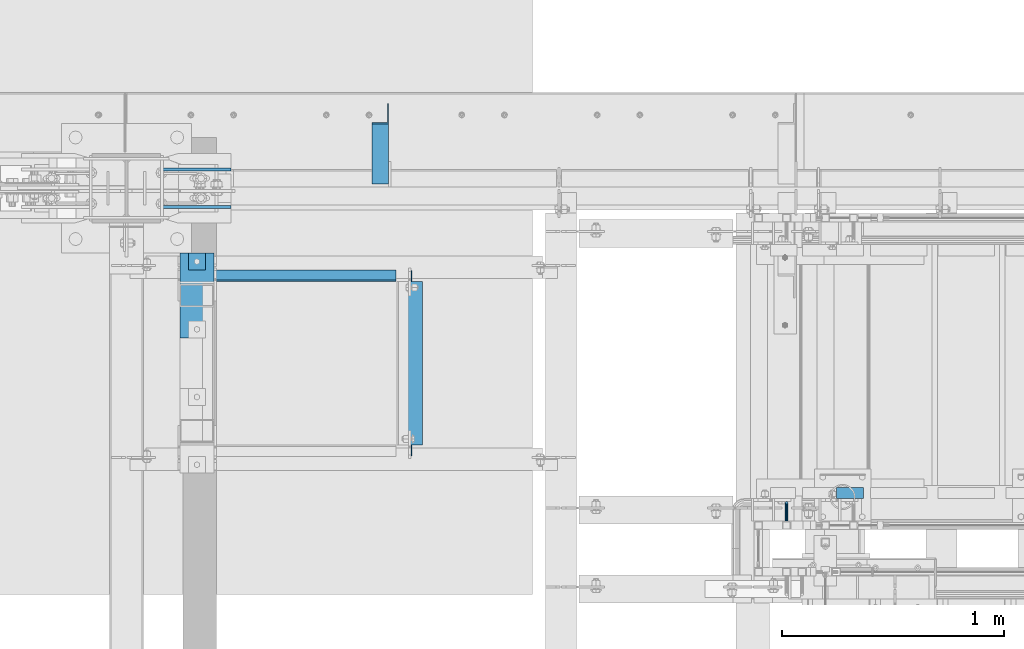
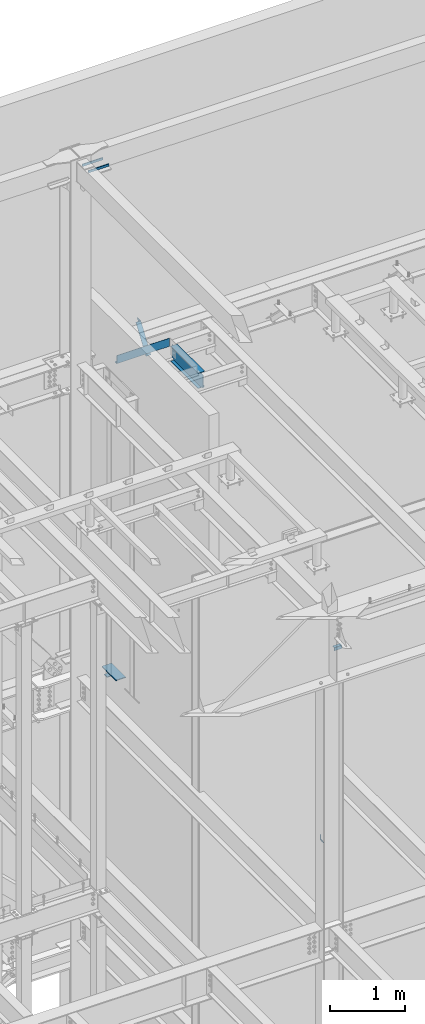
# One storey, part 928 of 1179: 8 beams, 1 member, 8 elements without a shape of their own.
"""IFC2X3 building model written with IfcOpenShell, lengths in millimetres."""

from ifc_helpers import new_model, si_unit, frame, origin_with_axes, place, context, subcontext, project, spatial, faceted_brep, material, type_object, element, aggregate, save


model = new_model("IFC2X3")

# Units and contexts
model_context = context("Model", 3, precision=1e-05, world=origin_with_axes())
body_context = subcontext(model_context, "Body", "Model", "MODEL_VIEW")
ifc_project = project(units=[si_unit("LENGTHUNIT", "METRE", prefix="MILLI"), si_unit("AREAUNIT", "SQUARE_METRE"), si_unit("VOLUMEUNIT", "CUBIC_METRE"), si_unit("MASSUNIT", "GRAM", prefix="KILO"), si_unit("TIMEUNIT", "SECOND"), si_unit("PLANEANGLEUNIT", "RADIAN"), si_unit("SOLIDANGLEUNIT", "STERADIAN"), si_unit("THERMODYNAMICTEMPERATUREUNIT", "DEGREE_CELSIUS"), si_unit("LUMINOUSINTENSITYUNIT", "LUMEN")], contexts=[model_context])

# Site, building, storey
site_placement = place(None, origin_with_axes())
site = spatial("IfcSite", under=ifc_project, at=site_placement, CompositionType="ELEMENT")
building_placement = place(site_placement, origin_with_axes())
building = spatial("IfcBuilding", under=site, at=building_placement, Name="Undefined", CompositionType="ELEMENT")
storey_placement = place(building_placement, origin_with_axes())
storey = spatial("IfcBuildingStorey", under=building, at=storey_placement, Name="Undefined", CompositionType="ELEMENT", Elevation=0.0)

# Assembly, beam
assembly_1_placement = place(storey_placement, origin_with_axes())
assembly_1 = element("IfcElementAssembly", 1, at=assembly_1_placement, inside=storey, Name="STAIR", AssemblyPlace="NOTDEFINED", PredefinedType="RIGID_FRAME")
ifc_material_1 = material(Name="STEEL/A36")
beam_type_1 = type_object("IfcBeamType", Name="L2X2X3/16", PredefinedType="NOTDEFINED")
beam_1_placement = place(assembly_1_placement, frame((19777.0749999898, 39827.2000000125, 8068.27050963414), z_axis=(0.0, 1.0, 0.0), x_axis=(-1.0, 0.0, 0.0)))
beam_1 = element("IfcBeam", 2, at=beam_1_placement, type_object=beam_type_1, material=ifc_material_1, Name="ANGLE", ObjectType="L2X2X3/16", context=body_context, shape_type="Brep", body=[
    faceted_brep([(0.0, 25.3999999999996, -25.4000000000015), (0.0, 25.3999999999996, 25.4000000000015), (120.650000000842, 25.3999999999996, 25.4000000000015), (120.650000000842, 25.3999999999996, -25.4000000000015), (0.0, 20.6374999999998, 25.4000000000015), (120.650000000842, 20.6374999999998, 25.4000000000015), (0.0, 20.6374999999998, -20.6374999999971), (120.650000000842, 20.6374999999998, -20.6374999999971), (0.0, -25.3999999999996, -20.6374999999971), (120.650000000842, -25.3999999999996, -20.6374999999971), (0.0, -25.3999999999996, -25.4000000000015), (120.650000000842, -25.3999999999996, -25.4000000000015)], [[[0, 1, 2, 3]], [[1, 4, 5, 2]], [[4, 6, 7, 5]], [[6, 8, 9, 7]], [[8, 10, 11, 9]], [[10, 0, 3, 11]], [[5, 7, 9, 11, 3, 2]], [[10, 8, 6, 4, 1, 0]]]),
])
aggregate(assembly_1, [beam_1])

assembly_2_placement = place(storey_placement, origin_with_axes())
assembly_2 = element("IfcElementAssembly", 3, at=assembly_2_placement, inside=storey, Name="GUARDRAIL", AssemblyPlace="NOTDEFINED", PredefinedType="RIGID_FRAME")
beam_type_2 = type_object("IfcBeamType", PredefinedType="NOTDEFINED")
beam_2_placement = place(assembly_2_placement, frame((19430.9999992195, 39700.200000778, 5054.6), z_axis=(0.0, 0.0, 1.0), x_axis=(0.0, 1.0, 0.0)))
beam_2 = element("IfcBeam", 4, at=beam_2_placement, type_object=beam_type_2, material=ifc_material_1, Name="BRACKET", context=body_context, shape_type="Brep", body=[
    faceted_brep([(0.0, -6.34999999999854, 0.0), (0.0, -4.49012806053361, -4.49012806053452), (69.849999425729, -4.49012806053361, -4.49012806053452), (69.849999425729, -6.34999999999854, 0.0), (0.0, 0.0, -6.34999999999991), (69.849999425729, 0.0, -6.34999999999991), (0.0, 4.49012806053361, -4.49012806053452), (69.849999425729, 4.49012806053361, -4.49012806053452), (0.0, 6.34999999999854, 0.0), (69.849999425729, 6.34999999999854, 0.0), (0.0, 4.49012806053361, 4.49012806053452), (69.849999425729, 4.49012806053361, 4.49012806053452), (0.0, 0.0, 6.34999999999991), (69.849999425729, 0.0, 6.34999999999991), (0.0, -4.49012806053361, 4.49012806053452), (69.849999425729, -4.49012806053361, 4.49012806053452), (79.3749993303718, 0.0, -3.79778396764323), (78.445063360632, -4.49012806053361, -2.18708762028064), (76.1999993303689, -6.34999999999854, 1.70147734638658), (73.9549353000984, -4.49012806053361, 5.59004231305425), (73.024999330366, 0.0, 7.20073866041639), (73.9549353000984, 4.49012806053361, 5.59004231305425), (76.1999993303689, 6.34999999999854, 1.70147734638658), (78.445063360632, 4.49012806053361, -2.18708762028064), (84.7370868552753, 4.49012806053361, 4.10493587436031), (86.3477832026401, 0.0, 3.17499990462693), (80.8485218886053, 6.34999999999854, 6.34999990462893), (76.9599569219426, 4.49012806053361, 8.59506393489755), (75.3492605745778, 0.0, 9.52499990463093), (76.9599569219426, -4.49012806053361, 8.59506393489755), (80.8485218886053, -6.34999999999854, 6.34999990462893), (84.7370868552753, -4.49012806053361, 4.10493587436031), (87.0401272955278, 4.49012806053361, 12.6999998092651), (88.8999992349927, 0.0, 12.6999998092651), (82.5499992349942, 6.34999999999854, 12.6999998092651), (78.0598711744606, 4.49012806053361, 12.6999998092651), (76.1999992349956, 0.0, 12.6999998092651), (78.0598711744606, -4.49012806053361, 12.6999998092651), (82.5499992349942, -6.34999999999854, 12.6999998092651), (87.0401272955278, -4.49012806053361, 12.6999998092651), (87.0401272955278, -4.49012806053361, 76.2000000000007), (82.5499992349942, -6.34999999999854, 76.2000000000007), (88.8999992349927, 0.0, 76.2000000000003), (87.0401272955278, 4.49012806053361, 76.2000000000007), (82.5499992349942, 6.34999999999854, 76.2000000000007), (78.0598711744606, 4.49012806053361, 76.2000000000007), (76.1999992349956, 0.0, 76.2000000000003), (78.0598711744606, -4.49012806053361, 76.2000000000007)], [[[0, 1, 2, 3]], [[1, 4, 5, 2]], [[4, 6, 7, 5]], [[6, 8, 9, 7]], [[8, 10, 11, 9]], [[10, 12, 13, 11]], [[12, 14, 15, 13]], [[14, 0, 3, 15]], [[14, 12, 10, 8, 6, 4, 1, 0]], [[2, 5, 16, 17]], [[3, 2, 17, 18]], [[15, 3, 18, 19]], [[13, 15, 19, 20]], [[11, 13, 20, 21]], [[9, 11, 21, 22]], [[7, 9, 22, 23]], [[5, 7, 23, 16]], [[23, 24, 25, 16]], [[22, 26, 24, 23]], [[21, 27, 26, 22]], [[20, 28, 27, 21]], [[19, 29, 28, 20]], [[18, 30, 29, 19]], [[17, 31, 30, 18]], [[16, 25, 31, 17]], [[24, 32, 33, 25]], [[26, 34, 32, 24]], [[27, 35, 34, 26]], [[28, 36, 35, 27]], [[29, 37, 36, 28]], [[30, 38, 37, 29]], [[31, 39, 38, 30]], [[25, 33, 39, 31]], [[38, 39, 40, 41]], [[39, 33, 42, 40]], [[33, 32, 43, 42]], [[32, 34, 44, 43]], [[34, 35, 45, 44]], [[35, 36, 46, 45]], [[36, 37, 47, 46]], [[37, 38, 41, 47]], [[42, 43, 44, 45, 46, 47, 41, 40]]]),
])
aggregate(assembly_2, [beam_2])

assembly_3_placement = place(storey_placement, origin_with_axes())
assembly_3 = element("IfcElementAssembly", 5, at=assembly_3_placement, inside=storey, Name="BEAM", AssemblyPlace="NOTDEFINED", PredefinedType="RIGID_FRAME")
beam_type_3 = type_object("IfcBeamType", PredefinedType="NOTDEFINED")
beam_3_placement = place(assembly_3_placement, frame((17265.65, 40782.875, 13252.4500061035), z_axis=(1.0, 0.0, 0.0), x_axis=(0.0, 0.0, -1.0)))
beam_3 = element("IfcBeam", 6, at=beam_3_placement, type_object=beam_type_3, material=ifc_material_1, Name="BENT_PLATE", context=body_context, shape_type="Brep", body=[
    faceted_brep([(0.0, -3.17500000000291, -406.400000000001), (0.0, -3.17500000000291, 406.400000000001), (0.0, 3.17500000000291, 406.400000000001), (0.0, 3.17500000000291, -406.400000000001), (127.000006103513, 3.17500000000291, 406.400000000001), (127.000006103513, 3.17500000000291, -406.400000000001), (133.350006103512, -3.17500000000291, -406.400000000001), (133.350006103512, -3.17500000000291, 406.400000000001), (127.000006103513, 47.6249999999927, 406.400000000001), (127.000006103513, 47.6249999999927, -406.400000000001), (133.350006103512, 47.6249999999927, 406.400000000001), (133.350006103512, 47.6249999999927, -406.400000000001)], [[[0, 1, 2, 3]], [[3, 2, 4, 5]], [[1, 0, 6, 7]], [[5, 4, 8, 9]], [[4, 2, 1, 7, 10, 8]], [[7, 6, 11, 10]], [[6, 0, 3, 5, 9, 11]], [[10, 11, 9, 8]]]),
])
aggregate(assembly_3, [beam_3])

assembly_4_placement = place(storey_placement, origin_with_axes())
assembly_4 = element("IfcElementAssembly", 7, at=assembly_4_placement, inside=storey, Name="BEAM", AssemblyPlace="NOTDEFINED", PredefinedType="RIGID_FRAME")
ifc_material_2 = material(Name="STEEL/A992")
beam_type_4 = type_object("IfcBeamType", Name="W10X12", PredefinedType="NOTDEFINED")
beam_4_placement = place(assembly_4_placement, frame((17741.9, 39979.6, 12993.6875), z_axis=(0.0, 0.0, 1.0), x_axis=(0.0, 1.0, 0.0)))
beam_4 = element("IfcBeam", 8, at=beam_4_placement, type_object=beam_type_4, material=ifc_material_2, Name="BEAM", ObjectType="W10X12", context=body_context, shape_type="Brep", body=[
    faceted_brep([(15.0812499999956, -2.38124999999854, -106.362500000001), (15.0812499999956, 2.38124999999854, -106.362500000001), (50.8000501907227, 2.38124999999854, -106.362500000001), (50.8000501907227, -2.38124999999854, -106.362500000001), (55.6601297087691, 2.38124999999854, -107.329229922589), (55.6601297087691, -2.38124999999854, -107.329229922589), (59.7803061769227, 2.38124999999854, -110.082243823066), (59.7803061769227, -2.38124999999854, -110.082243823066), (62.5333200773966, 2.38124999999854, -114.20242029122), (62.5333200773966, -2.38124999999854, -114.20242029122), (63.5000499999878, -2.38124999999854, -119.062499809266), (63.5000499999878, 2.38124999999854, -119.062499809266), (63.5000499999878, 2.38124999999854, -120.65), (63.5000499999878, 50.7999999999993, -120.65), (63.5000499999878, 50.7999999999993, -125.4125), (63.5000499999878, -50.7999999999993, -125.4125), (63.5000499999878, -50.7999999999993, -120.65), (63.5000499999878, -2.38124999999854, -120.65), (800.099950000003, 50.7999999999993, 120.65), (800.099950000003, 2.38124999999854, 120.65), (63.5000499999878, 2.38124999999854, 120.65), (63.5000499999878, 50.7999999999993, 120.65), (50.8000501907227, -2.38124999999854, 106.362499999999), (50.8000501907227, 2.38124999999854, 106.362499999999), (15.0812499999956, 2.38124999999854, 106.362499999999), (15.0812499999956, -2.38124999999854, 106.362499999999), (55.6601297087691, -2.38124999999854, 107.329229922587), (55.6601297087691, 2.38124999999854, 107.329229922587), (59.7803061769227, -2.38124999999854, 110.082243823064), (59.7803061769227, 2.38124999999854, 110.082243823064), (62.5333200773966, -2.38124999999854, 114.202420291218), (62.5333200773966, 2.38124999999854, 114.202420291218), (63.5000499999878, -2.38124999999854, 119.062499809264), (63.5000499999878, 2.38124999999854, 119.062499809264), (800.099950000003, -50.7999999999993, 125.4125), (800.099950000003, 50.7999999999993, 125.4125), (63.5000499999878, 50.7999999999993, 125.4125), (63.5000499999878, -50.7999999999993, 125.4125), (800.099950000003, -50.7999999999993, 120.65), (63.5000499999878, -50.7999999999993, 120.65), (800.099950000003, -2.38124999999854, 120.65), (63.5000499999878, -2.38124999999854, 120.65), (800.099950000003, -2.38124999999854, 119.062499809264), (800.099950000003, 2.38124999999854, 119.062499809264), (801.066679922595, -2.38124999999854, 114.202420291218), (801.066679922595, 2.38124999999854, 114.202420291218), (803.819693823069, -2.38124999999854, 110.082243823064), (803.819693823069, 2.38124999999854, 110.082243823064), (807.939870291222, -2.38124999999854, 107.329229922587), (807.939870291222, 2.38124999999854, 107.329229922587), (812.799949809269, -2.38124999999854, 106.362499999999), (812.799949809269, 2.38124999999854, 106.362499999999), (848.518750000003, -2.38124999999854, 106.362499999999), (848.518750000003, 2.38124999999854, 106.362499999999), (848.518750000003, -2.38124999999854, -106.362500000001), (848.518750000003, 2.38124999999854, -106.362500000001), (812.799949809269, -2.38124999999854, -106.362500000001), (812.799949809269, 2.38124999999854, -106.362500000001), (807.939870291222, -2.38124999999854, -107.329229922589), (807.939870291222, 2.38124999999854, -107.329229922589), (803.819693823069, -2.38124999999854, -110.082243823066), (803.819693823069, 2.38124999999854, -110.082243823066), (801.066679922595, -2.38124999999854, -114.20242029122), (801.066679922595, 2.38124999999854, -114.20242029122), (800.099950000003, -2.38124999999854, -119.062499809266), (800.099950000003, 2.38124999999854, -119.062499809266), (800.099950000003, -2.38124999999854, -120.65), (800.099950000003, -50.7999999999993, -120.65), (800.099950000003, -50.7999999999993, -125.4125), (800.099950000003, 50.7999999999993, -125.4125), (800.099950000003, 50.7999999999993, -120.65), (800.099950000003, 2.38124999999854, -120.65)], [[[0, 1, 2, 3]], [[3, 2, 4, 5]], [[5, 4, 6, 7]], [[7, 6, 8, 9]], [[10, 11, 12, 13, 14, 15, 16, 17]], [[9, 8, 11, 10]], [[18, 19, 20, 21]], [[22, 23, 24, 25]], [[26, 27, 23, 22]], [[28, 29, 27, 26]], [[30, 31, 29, 28]], [[32, 33, 31, 30]], [[34, 35, 36, 37]], [[38, 34, 37, 39]], [[40, 38, 39, 41]], [[37, 36, 21, 20, 33, 32, 41, 39]], [[35, 18, 21, 36]], [[34, 38, 40, 42, 43, 19, 18, 35]], [[44, 45, 43, 42]], [[46, 47, 45, 44]], [[48, 49, 47, 46]], [[50, 51, 49, 48]], [[52, 53, 51, 50]], [[53, 52, 54, 55]], [[54, 56, 57, 55]], [[58, 59, 57, 56]], [[60, 61, 59, 58]], [[62, 63, 61, 60]], [[64, 65, 63, 62]], [[66, 67, 68, 69, 70, 71, 65, 64]], [[67, 66, 17, 16]], [[68, 67, 16, 15]], [[69, 68, 15, 14]], [[70, 69, 14, 13]], [[71, 70, 13, 12]], [[6, 4, 2, 1, 24, 23, 27, 29, 31, 33, 20, 19, 43, 45, 47, 49, 51, 53, 55, 57, 59, 61, 63, 65, 71, 12, 11, 8]], [[25, 24, 1, 0]], [[66, 64, 62, 60, 58, 56, 54, 52, 50, 48, 46, 44, 42, 40, 41, 32, 30, 28, 26, 22, 25, 0, 3, 5, 7, 9, 10, 17]]]),
])
aggregate(assembly_4, [beam_4])

# Assembly, member
assembly_5_placement = place(storey_placement, origin_with_axes())
assembly_5 = element("IfcElementAssembly", 9, at=assembly_5_placement, inside=storey, Name="ANGLE", AssemblyPlace="NOTDEFINED", PredefinedType="RIGID_FRAME")
member_type = type_object("IfcMemberType", Name="L3X3X1/4", PredefinedType="NOTDEFINED")
member_placement = place(assembly_5_placement, frame((17602.2, 41248.3636551318, 12707.4244380128), z_axis=(0.0, 0.821716663099518, -0.569896241069015), x_axis=(0.0, 0.569896241069016, 0.821716663099518)))
member = element("IfcMember", 10, at=member_placement, type_object=member_type, material=ifc_material_1, Name="ANGLE", ObjectType="L3X3X1/4", context=body_context, shape_type="Brep", body=[
    faceted_brep([(0.0, -38.0999999999985, -38.0999999999999), (0.0, -38.0999999999985, -31.75), (0.0, 31.75, -31.75), (0.0, 31.75, 38.1000000000004), (0.0, 38.0999999999985, 38.0999999999999), (0.0, 38.0999999999985, -38.0999999999999), (527.418547333735, 31.75, 38.0999999993364), (527.418547333735, 38.1000000000004, 38.0999999993364), (474.570533511644, 38.1000000000004, -38.1000000006607), (474.570533511644, -38.1000000000004, -38.1000000006607), (478.974534663488, -38.1000000000004, -31.7500000006621), (478.974534663488, 31.75, -31.7500000006621)], [[[0, 1, 2, 3, 4, 5]], [[4, 3, 6, 7]], [[5, 4, 7, 8]], [[0, 5, 8, 9]], [[1, 0, 9, 10]], [[2, 1, 10, 11]], [[3, 2, 11, 6]], [[10, 9, 8, 7, 6, 11]]]),
])
aggregate(assembly_5, [member])

# Assembly, beam
assembly_6_placement = place(storey_placement, origin_with_axes())
assembly_6 = element("IfcElementAssembly", 11, at=assembly_6_placement, inside=storey, Name="EMBED PLATE", AssemblyPlace="NOTDEFINED", PredefinedType="RIGID_FRAME")
ifc_material_3 = material(Name="STEEL/A572-GR.50")
beam_type_5 = type_object("IfcBeamType", PredefinedType="NOTDEFINED")
beam_5_placement = place(assembly_6_placement, frame((16700.5, 40716.2, 8153.4), z_axis=(0.0, -1.0, 0.0), x_axis=(1.0, 0.0, 0.0)))
beam_5 = element("IfcBeam", 12, at=beam_5_placement, type_object=beam_type_5, material=ifc_material_3, Name="EMBED PLATE", context=body_context, shape_type="Brep", body=[
    faceted_brep([(0.0, 6.35000000000036, -190.5), (0.0, 6.35000000000036, 190.5), (152.400000000001, 6.35000000000036, 190.5), (152.400000000001, 6.35000000000036, -190.5), (0.0, -6.35000000000036, 190.5), (152.400000000001, -6.35000000000036, 190.5), (0.0, -6.35000000000036, -190.5), (152.400000000001, -6.35000000000036, -190.5)], [[[0, 1, 2, 3]], [[1, 4, 5, 2]], [[4, 6, 7, 5]], [[6, 0, 3, 7]], [[5, 7, 3, 2]], [[6, 4, 1, 0]]]),
])
aggregate(assembly_6, [beam_5])

# Assembly, beams
assembly_7_placement = place(storey_placement, origin_with_axes())
assembly_7 = element("IfcElementAssembly", 13, at=assembly_7_placement, inside=storey, Name="COLUMN", AssemblyPlace="NOTDEFINED", PredefinedType="RIGID_FRAME")
beam_type_6 = type_object("IfcBeamType", PredefinedType="NOTDEFINED")
beam_6_placement = place(assembly_7_placement, frame((16930.6875, 41114.6625, 16141.7), z_axis=(0.0, 0.0, 1.0), x_axis=(-1.0, 0.0, 0.0)))
beam_6 = element("IfcBeam", 14, at=beam_6_placement, type_object=beam_type_6, material=ifc_material_1, Name="PLATE", context=body_context, shape_type="Brep", body=[
    faceted_brep([(0.0, 6.34999999999854, -19.0499999999993), (0.0, 6.35000000000036, 19.0499999999993), (317.5, 6.34999999999854, 19.0499999999993), (317.5, 6.34999999999854, -19.0499999999993), (0.0, -6.35000000000036, 19.0499999999993), (317.5, -6.34999999999854, 19.0499999999993), (0.0, -6.34999999999854, -19.0499999999993), (317.5, -6.34999999999854, -19.0499999999993)], [[[0, 1, 2, 3]], [[1, 4, 5, 2]], [[4, 6, 7, 5]], [[6, 0, 3, 7]], [[5, 7, 3, 2]], [[6, 4, 1, 0]]]),
])
beam_7_placement = place(assembly_7_placement, frame((16930.6875, 41282.9375, 16141.7), z_axis=(0.0, 0.0, 1.0), x_axis=(-1.0, 0.0, 0.0)))
beam_7 = element("IfcBeam", 15, at=beam_7_placement, type_object=beam_type_6, material=ifc_material_1, Name="PLATE", context=body_context, shape_type="Brep", body=[
    faceted_brep([(0.0, 6.34999999999854, -19.0499999999993), (0.0, 6.35000000000036, 19.0499999999993), (317.5, 6.34999999999854, 19.0499999999993), (317.5, 6.34999999999854, -19.0499999999993), (0.0, -6.35000000000036, 19.0499999999993), (317.5, -6.34999999999854, 19.0499999999993), (0.0, -6.34999999999854, -19.0499999999993), (317.5, -6.34999999999854, -19.0499999999993)], [[[0, 1, 2, 3]], [[1, 4, 5, 2]], [[4, 6, 7, 5]], [[6, 0, 3, 7]], [[5, 7, 3, 2]], [[6, 4, 1, 0]]]),
])
aggregate(assembly_7, [beam_6, beam_7])

# Assembly, beam
assembly_8_placement = place(storey_placement, origin_with_axes())
assembly_8 = element("IfcElementAssembly", 16, at=assembly_8_placement, inside=storey, Name="PLATE", AssemblyPlace="NOTDEFINED", PredefinedType="RIGID_FRAME")
beam_type_7 = type_object("IfcBeamType", PredefinedType="NOTDEFINED")
beam_8_placement = place(assembly_8_placement, frame((16738.6, 40868.6, 8008.9375), z_axis=(0.0, -1.0, 0.0), x_axis=(1.0, 0.0, 0.0)))
beam_8 = element("IfcBeam", 17, at=beam_8_placement, type_object=beam_type_7, material=ifc_material_1, Name="PLATE", context=body_context, shape_type="Brep", body=[
    faceted_brep([(1.81898940354586e-12, 4.76249999999891, -38.0999999999985), (0.0, 4.76250000000073, 38.0999999999985), (76.2000000000007, 4.76249999999982, 38.0999999999985), (76.2000000000007, 4.76249999999982, -38.0999999999985), (0.0, -4.76250000000073, 38.0999999999985), (76.2000000000007, -4.76249999999982, 38.0999999999985), (-9.09494701772928e-13, -4.76250000000073, -38.0999999999985), (76.2000000000007, -4.76249999999982, -38.0999999999985)], [[[0, 1, 2, 3]], [[1, 4, 5, 2]], [[4, 6, 7, 5]], [[6, 0, 3, 7]], [[5, 7, 3, 2]], [[6, 4, 1, 0]]]),
])
aggregate(assembly_8, [beam_8])

save(model, "model.ifc")
